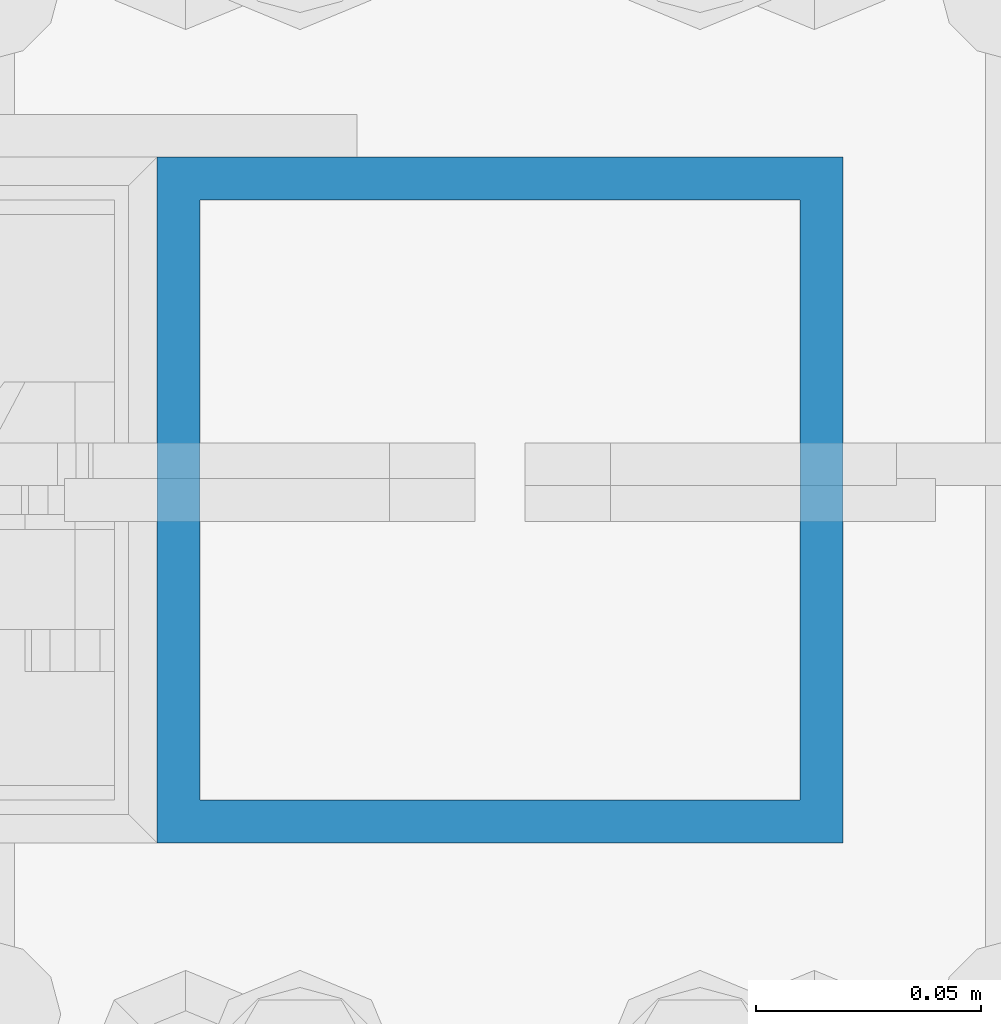
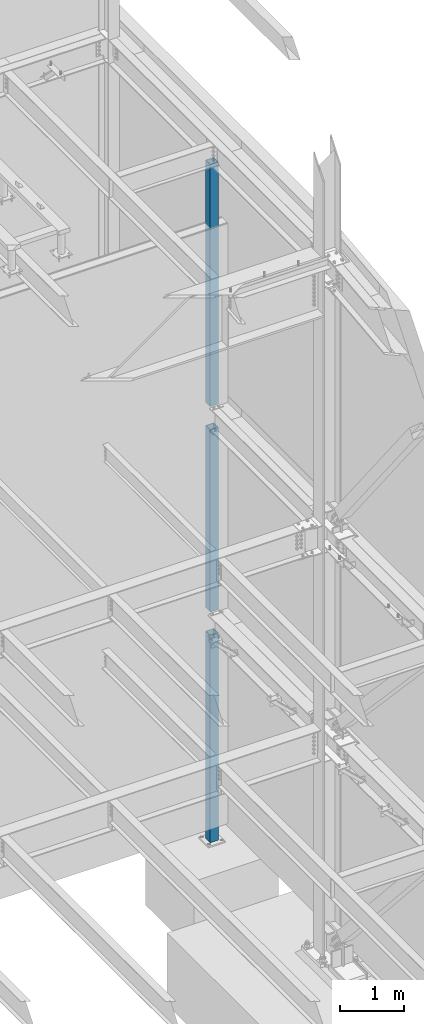
# One storey, part 374 of 1179: 3 columns, 3 elements without a shape of their own.
"""IFC2X3 building model written with IfcOpenShell, lengths in millimetres."""

import ifcopenshell
import ifcopenshell.guid

model = None  # the IFC model being written
_history = None  # IfcOwnerHistory: only IFC2X3 demands one
_inside = {}  # id of a spatial element -> (the spatial element, [elements in it])
_under = {}  # id of a project, library or spatial element -> (it, [spatial elements below it])
_declared = {}  # id of a project -> (the project, [libraries it declares])
_typed = {}  # id of a type object -> (the type object, [elements of that type])
_made_of = {}  # id of a material, layer set ... -> (it, [elements and type objects made of it])


def new_model(schema):
    """Start an empty IFC model of exactly this schema.

    Asked for "IFC4X3", IfcOpenShell would pick the latest addendum, in which some entities
    have other attributes; the version numbers below select the first issue.
    IFC2X3 requires an IfcOwnerHistory on every rooted entity: one is made here for all.
    """
    global model, _history
    if schema == "IFC4X3":
        model = ifcopenshell.file(schema_version=(4, 3, 0, 0))
    else:
        model = ifcopenshell.file(schema=schema)
    _inside.clear()
    _under.clear()
    _declared.clear()
    _typed.clear()
    _made_of.clear()
    _history = None
    if model.schema == "IFC2X3":
        org = make("IfcOrganization", Name="unknown")
        user = make(
            "IfcPersonAndOrganization",
            ThePerson=make("IfcPerson", FamilyName="unknown"),
            TheOrganization=org,
        )
        app = make(
            "IfcApplication",
            ApplicationDeveloper=org,
            Version="unknown",
            ApplicationFullName="unknown",
            ApplicationIdentifier="unknown",
        )
        _history = make(
            "IfcOwnerHistory",
            OwningUser=user,
            OwningApplication=app,
            ChangeAction="ADDED",
            CreationDate=0,
        )
    return model


def make(cls, **values):
    """One entity of the class cls with the attributes given. An attribute that is None is left unset."""
    return model.create_entity(
        cls, **{name: value for name, value in values.items() if value is not None}
    )


def rooted(cls, **values):
    """An entity with a GlobalId (a new one), such as an element, a storey or a relation."""
    return make(cls, GlobalId=ifcopenshell.guid.new(), OwnerHistory=_history, **values)


def si_unit(unit_type, name, prefix=None):
    """IfcSIUnit, for example si_unit("LENGTHUNIT", "METRE", prefix="MILLI")."""
    return make("IfcSIUnit", UnitType=unit_type, Prefix=prefix, Name=name)


def assignment(units):
    """IfcUnitAssignment: the units of a project."""
    return None if units is None else make("IfcUnitAssignment", Units=units)


def point(xyz):
    """IfcCartesianPoint."""
    return None if xyz is None else make("IfcCartesianPoint", Coordinates=xyz)


def direction(xyz):
    """IfcDirection."""
    return None if xyz is None else make("IfcDirection", DirectionRatios=xyz)


def frame(location, z_axis=None, x_axis=None):
    """IfcAxis2Placement3D, a coordinate frame: its origin and axes. An axis left out is left unset."""
    return make(
        "IfcAxis2Placement3D",
        Location=point(location),
        Axis=direction(z_axis),
        RefDirection=direction(x_axis),
    )


def origin_with_axes():
    """The frame at (0, 0, 0) with the z axis (0, 0, 1) and the x axis (1, 0, 0) written out."""
    return frame((0.0, 0.0, 0.0), z_axis=(0.0, 0.0, 1.0), x_axis=(1.0, 0.0, 0.0))


def place(relative_to, where):
    """IfcLocalPlacement: puts the frame where relative to a parent placement (None: the world)."""
    return make(
        "IfcLocalPlacement", PlacementRelTo=relative_to, RelativePlacement=where
    )


def context(
    kind, dimensions, precision=None, world=None, true_north=None, identifier=None
):
    """IfcGeometricRepresentationContext, for example the 3D "Model" context."""
    return make(
        "IfcGeometricRepresentationContext",
        ContextIdentifier=identifier,
        ContextType=kind,
        CoordinateSpaceDimension=dimensions,
        Precision=precision,
        WorldCoordinateSystem=world,
        TrueNorth=true_north,
    )


def subcontext(parent, identifier, kind, view, scale=None):
    """IfcGeometricRepresentationSubContext, for example "Body" below "Model"."""
    return make(
        "IfcGeometricRepresentationSubContext",
        ContextIdentifier=identifier,
        ContextType=kind,
        ParentContext=parent,
        TargetScale=scale,
        TargetView=view,
    )


def project(units=None, contexts=None):
    """IfcProject with its units and contexts."""
    return rooted(
        "IfcProject",
        Name="project",
        RepresentationContexts=contexts,
        UnitsInContext=assignment(units),
    )


def spatial(cls, under=None, at=None, **own):
    """A site, building, storey or space (cls), placed at a placement, below another one or the project."""
    s = rooted(cls, ObjectPlacement=at, **own)
    if under is not None:
        _under.setdefault(under.id(), (under, []))[1].append(s)
    return s


def faces_of(points, faces, orient=None, outer=None):
    """IfcFace entities. A face is a list of loops; a loop is a list of indices into points, from 0.

    orient and outer hold one flag for each loop. By default every Orientation is true, the
    first loop of a face is its IfcFaceOuterBound and the others are IfcFaceBound.
    """
    made = []
    for i, loops in enumerate(faces):
        bounds = []
        for j, loop in enumerate(loops):
            is_outer = j == 0 if outer is None else outer[i][j]
            bounds.append(
                make(
                    "IfcFaceOuterBound" if is_outer else "IfcFaceBound",
                    Bound=make("IfcPolyLoop", Polygon=[points[k] for k in loop]),
                    Orientation=True if orient is None else orient[i][j],
                )
            )
        made.append(make("IfcFace", Bounds=bounds))
    return made


def faceted_brep(points, faces, orient=None, outer=None, voids=None):
    """IfcFacetedBrep: a solid bounded by flat faces; with voids (closed shells), ...WithVoids."""
    shared = [point(p) for p in points]
    hull = make("IfcClosedShell", CfsFaces=faces_of(shared, faces, orient, outer))
    if voids is None:
        return make("IfcFacetedBrep", Outer=hull)
    return make(
        "IfcFacetedBrepWithVoids",
        Outer=hull,
        Voids=[
            make(cls, CfsFaces=faces_of(shared, fs, o, b)) for cls, fs, o, b in voids
        ],
    )


def shape(context_of_items, identifier, shape_type, items):
    """IfcShapeRepresentation: the items that make up one representation, for example the "Body"."""
    return make(
        "IfcShapeRepresentation",
        ContextOfItems=context_of_items,
        RepresentationIdentifier=identifier,
        RepresentationType=shape_type,
        Items=items,
    )


def material(Name=None, Category=None):
    """IfcMaterial."""
    return make("IfcMaterial", Name=Name, Category=Category)


def made_of(thing, what):
    """Note that an element or type object is made of a material, layer set ...; save() writes the relation."""
    if what is not None:
        _made_of.setdefault(what.id(), (what, []))[1].append(thing)
    return thing


def type_object(cls, material=None, **own):
    """A type object (cls), such as IfcWallType, which elements share."""
    return made_of(rooted(cls, **own), material)


def element(
    cls,
    number,
    at=None,
    inside=None,
    cuts=None,
    type_object=None,
    material=None,
    context=None,
    identifier="Body",
    shape_type=None,
    held_by="IfcProductDefinitionShape",
    body=None,
    shapes=None,
    **own,
):
    """One element of the class cls, such as IfcWall. Its Tag is "e" and its number.

    at: its placement. inside: the storey or other place that contains it. cuts: it is an
    opening in that element (IfcRelVoidsElement). A single representation is given by context,
    identifier, shape_type and body (its items); several are given by shapes. held_by: the class
    of the entity that holds the representations. save() writes the other relations.
    """
    e = rooted(cls, Tag="e%d" % number, ObjectPlacement=at, **own)
    if body is not None:
        shapes = [shape(context, identifier, shape_type, body)]
    if shapes is not None:
        e.Representation = make(held_by, Representations=shapes)
    if inside is not None:
        _inside.setdefault(inside.id(), (inside, []))[1].append(e)
    if cuts is not None:
        rooted(
            "IfcRelVoidsElement", RelatingBuildingElement=cuts, RelatedOpeningElement=e
        )
    if type_object is not None:
        _typed.setdefault(type_object.id(), (type_object, []))[1].append(e)
    return made_of(e, material)


def aggregate(whole, parts):
    """IfcRelAggregates: a whole, such as a stair, and the parts it consists of."""
    return rooted("IfcRelAggregates", RelatingObject=whole, RelatedObjects=parts)


def save(model, path):
    """Write the relations noted so far, then the file.

    IfcRelAggregates (storeys below a building ...), IfcRelContainedInSpatialStructure (elements
    in a storey), IfcRelDefinesByType, IfcRelAssociatesMaterial and IfcRelDeclares: one each for
    every whole, place, type object, material and project.
    """
    for whole, parts in _under.values():
        aggregate(whole, parts)
    for where, things in _inside.values():
        rooted(
            "IfcRelContainedInSpatialStructure",
            RelatedElements=things,
            RelatingStructure=where,
        )
    for kind, things in _typed.values():
        rooted("IfcRelDefinesByType", RelatedObjects=things, RelatingType=kind)
    for what, things in _made_of.values():
        rooted("IfcRelAssociatesMaterial", RelatedObjects=things, RelatingMaterial=what)
    for by, libraries in _declared.values():
        rooted("IfcRelDeclares", RelatingContext=by, RelatedDefinitions=libraries)
    model.write(path)


model = new_model("IFC2X3")

# Units and contexts
model_context = context("Model", 3, precision=1e-05, world=origin_with_axes())
body_context = subcontext(model_context, "Body", "Model", "MODEL_VIEW")
ifc_project = project(units=[si_unit("LENGTHUNIT", "METRE", prefix="MILLI"), si_unit("AREAUNIT", "SQUARE_METRE"), si_unit("VOLUMEUNIT", "CUBIC_METRE"), si_unit("MASSUNIT", "GRAM", prefix="KILO"), si_unit("TIMEUNIT", "SECOND"), si_unit("PLANEANGLEUNIT", "RADIAN"), si_unit("SOLIDANGLEUNIT", "STERADIAN"), si_unit("THERMODYNAMICTEMPERATUREUNIT", "DEGREE_CELSIUS"), si_unit("LUMINOUSINTENSITYUNIT", "LUMEN")], contexts=[model_context])

# Site, building, storey
site_placement = place(None, origin_with_axes())
site = spatial("IfcSite", under=ifc_project, at=site_placement, CompositionType="ELEMENT")
building_placement = place(site_placement, origin_with_axes())
building = spatial("IfcBuilding", under=site, at=building_placement, Name="Undefined", CompositionType="ELEMENT")
storey_placement = place(building_placement, origin_with_axes())
storey = spatial("IfcBuildingStorey", under=building, at=storey_placement, Name="Undefined", CompositionType="ELEMENT", Elevation=0.0)

# Assembly, column
assembly_1_placement = place(storey_placement, origin_with_axes())
assembly_1 = element("IfcElementAssembly", 1, at=assembly_1_placement, inside=storey, Name="COLUMN", AssemblyPlace="NOTDEFINED", PredefinedType="RIGID_FRAME")
ifc_material = material()
column_type = type_object("IfcColumnType", Name="HSS6X6X3/8", PredefinedType="NOTDEFINED")
column_1_placement = place(assembly_1_placement, frame((24307.8, 37985.7, 8013.7), z_axis=(0.0, 1.0, 0.0), x_axis=(0.0, 0.0, 1.0)))
column_1 = element("IfcColumn", 2, at=column_1_placement, type_object=column_type, material=ifc_material, Name="COLUMN", ObjectType="HSS6X6X3/8", context=body_context, shape_type="Brep", body=[
    faceted_brep([(12.6999999999998, 66.6749999999993, -66.6750000000029), (12.6999999999998, -66.6749999999993, -66.6750000000029), (4619.625, -66.6749999999993, -66.6750000000029), (4619.625, 66.6749999999993, -66.6750000000029), (12.6999999999998, -66.6749999999993, 66.6750000000029), (4619.625, -66.6749999999993, 66.6750000000029), (12.6999999999998, 66.6749999999993, 66.6750000000029), (4619.625, 66.6749999999993, 66.6750000000029), (12.6999999999998, 76.2000000000007, -76.1999999999971), (12.6999999999998, 76.2000000000007, 76.1999999999971), (4619.625, 76.2000000000007, 76.1999999999971), (4619.625, 76.2000000000007, -76.1999999999971), (12.6999999999998, -76.2000000000007, 76.1999999999971), (4619.625, -76.2000000000007, 76.1999999999971), (12.6999999999998, -76.2000000000007, -76.1999999999971), (4619.625, -76.2000000000007, -76.1999999999971)], [[[0, 1, 2, 3]], [[1, 4, 5, 2]], [[4, 6, 7, 5]], [[6, 0, 3, 7]], [[8, 9, 10, 11]], [[9, 12, 13, 10]], [[12, 14, 15, 13]], [[14, 8, 11, 15]], [[13, 15, 11, 10], [5, 7, 3, 2]], [[14, 12, 9, 8], [6, 4, 1, 0]]]),
])
aggregate(assembly_1, [column_1])

assembly_2_placement = place(storey_placement, origin_with_axes())
assembly_2 = element("IfcElementAssembly", 3, at=assembly_2_placement, inside=storey, Name="COLUMN", AssemblyPlace="NOTDEFINED", PredefinedType="RIGID_FRAME")
column_2_placement = place(assembly_2_placement, frame((24307.8, 37985.7, 4102.1), z_axis=(0.0, 1.0, 0.0), x_axis=(0.0, 0.0, 1.0)))
column_2 = element("IfcColumn", 4, at=column_2_placement, type_object=column_type, material=ifc_material, Name="COLUMN", ObjectType="HSS6X6X3/8", context=body_context, shape_type="Brep", body=[
    faceted_brep([(12.6999999999998, 66.6749999999993, -66.6750000000029), (12.6999999999998, -66.6749999999993, -66.6750000000029), (3476.625, -66.6749999999993, -66.6750000000029), (3476.625, 66.6749999999993, -66.6750000000029), (12.6999999999998, -66.6749999999993, 66.6750000000029), (3476.625, -66.6749999999993, 66.6750000000029), (12.6999999999998, 66.6749999999993, 66.6750000000029), (3476.625, 66.6749999999993, 66.6750000000029), (12.6999999999998, 76.2000000000007, -76.1999999999971), (12.6999999999998, 76.2000000000007, 76.1999999999971), (3476.625, 76.2000000000007, 76.1999999999971), (3476.625, 76.2000000000007, -76.1999999999971), (12.6999999999998, -76.2000000000007, 76.1999999999971), (3476.625, -76.2000000000007, 76.1999999999971), (12.6999999999998, -76.2000000000007, -76.1999999999971), (3476.625, -76.2000000000007, -76.1999999999971)], [[[0, 1, 2, 3]], [[1, 4, 5, 2]], [[4, 6, 7, 5]], [[6, 0, 3, 7]], [[8, 9, 10, 11]], [[9, 12, 13, 10]], [[12, 14, 15, 13]], [[14, 8, 11, 15]], [[13, 15, 11, 10], [5, 7, 3, 2]], [[14, 12, 9, 8], [6, 4, 1, 0]]]),
])
aggregate(assembly_2, [column_2])

assembly_3_placement = place(storey_placement, origin_with_axes())
assembly_3 = element("IfcElementAssembly", 5, at=assembly_3_placement, inside=storey, Name="COLUMN", AssemblyPlace="NOTDEFINED", PredefinedType="RIGID_FRAME")
column_3_placement = place(assembly_3_placement, frame((24307.8, 37985.7, -355.6), z_axis=(0.0, 1.0, 0.0), x_axis=(0.0, 0.0, 1.0)))
column_3 = element("IfcColumn", 6, at=column_3_placement, type_object=column_type, material=ifc_material, Name="COLUMN", ObjectType="HSS6X6X3/8", context=body_context, shape_type="Brep", body=[
    faceted_brep([(76.2000000000008, 66.675000000112, -66.6749999999902), (76.2000000000008, -66.6750000001084, -66.6750000000175), (4019.55, -66.6749999999993, -66.6750000000029), (4019.55, 66.6749999999993, -66.6750000000029), (76.2000000000008, -66.6750000001011, 66.674999999992), (4019.55, -66.6749999999993, 66.6750000000029), (76.2000000000008, 66.6750000001193, 66.6750000000193), (4019.55, 66.6749999999993, 66.6750000000029), (76.2000000000008, 76.2000000001281, -76.1999999999898), (76.2000000000008, 76.2000000001317, 76.2000000000216), (4019.55, 76.2000000000007, 76.1999999999971), (4019.55, 76.2000000000007, -76.1999999999971), (76.2000000000008, -76.2000000001171, 76.1999999999916), (4019.55, -76.2000000000007, 76.1999999999971), (76.2000000000008, -76.2000000001208, -76.2000000000198), (4019.55, -76.2000000000007, -76.1999999999971)], [[[0, 1, 2, 3]], [[1, 4, 5, 2]], [[4, 6, 7, 5]], [[6, 0, 3, 7]], [[8, 9, 10, 11]], [[9, 12, 13, 10]], [[12, 14, 15, 13]], [[14, 8, 11, 15]], [[13, 15, 11, 10], [5, 7, 3, 2]], [[14, 12, 9, 8], [6, 4, 1, 0]]]),
])
aggregate(assembly_3, [column_3])

save(model, "model.ifc")
